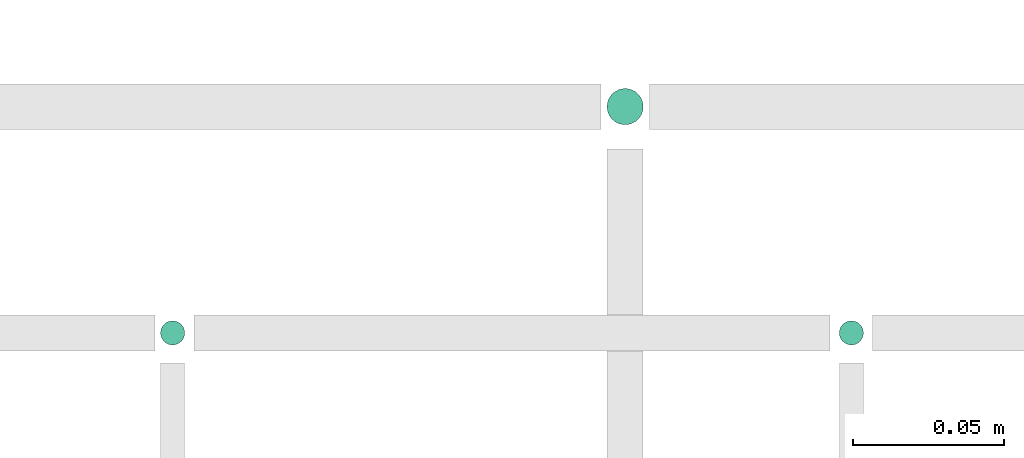
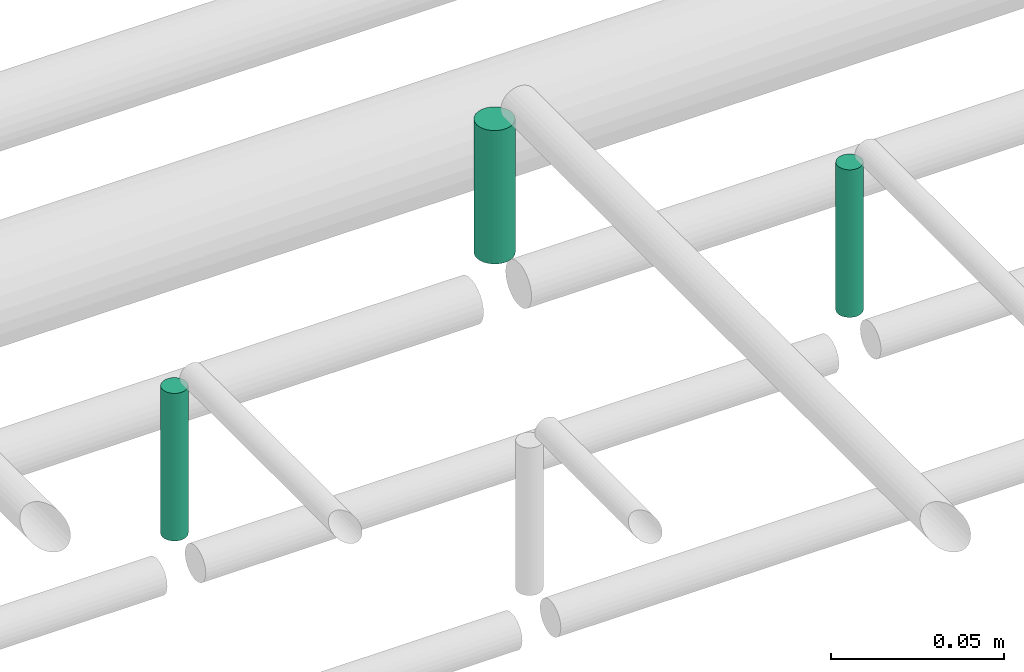
# One storey, part 282 of 331: 3 flow segments.
"""IFC2X3 building model written with IfcOpenShell, lengths in millimetres."""

from ifc_helpers import new_model, entity, si_unit, converted_unit, derived_unit, direction, frame, frame_2d, origin, origin_2d_with_axis, place, context, subcontext, project, spatial, circle, extrude, type_object, element, save


model = new_model("IFC2X3")

# Units and contexts
model_context = context("Model", 3, precision=0.01, world=origin(), true_north=direction((6.12303176911189e-17, 1.0)))
body_context = subcontext(model_context, "Body", "Model", "MODEL_VIEW")
ifc_project = project(units=[si_unit("LENGTHUNIT", "METRE", prefix="MILLI"), si_unit("AREAUNIT", "SQUARE_METRE"), si_unit("VOLUMEUNIT", "CUBIC_METRE"), converted_unit("PLANEANGLEUNIT", "DEGREE", entity("IfcRatioMeasure", 0.0174532925199433), si_unit("PLANEANGLEUNIT", "RADIAN"), dimensions=[0, 0, 0, 0, 0, 0, 0]), si_unit("MASSUNIT", "GRAM", prefix="KILO"), derived_unit("MASSDENSITYUNIT", [(si_unit("MASSUNIT", "GRAM", prefix="KILO"), 1), (si_unit("LENGTHUNIT", "METRE"), -3)]), derived_unit("MOMENTOFINERTIAUNIT", [(si_unit("LENGTHUNIT", "METRE"), 4)]), si_unit("TIMEUNIT", "SECOND"), si_unit("FREQUENCYUNIT", "HERTZ"), si_unit("THERMODYNAMICTEMPERATUREUNIT", "DEGREE_CELSIUS"), derived_unit("THERMALTRANSMITTANCEUNIT", [(si_unit("MASSUNIT", "GRAM", prefix="KILO"), 1), (si_unit("THERMODYNAMICTEMPERATUREUNIT", "KELVIN"), -1), (si_unit("TIMEUNIT", "SECOND"), -3)]), derived_unit("VOLUMETRICFLOWRATEUNIT", [(si_unit("LENGTHUNIT", "METRE"), 3), (si_unit("TIMEUNIT", "SECOND"), -1)]), derived_unit("MASSFLOWRATEUNIT", [(si_unit("MASSUNIT", "GRAM", prefix="KILO"), 1), (si_unit("TIMEUNIT", "SECOND"), -1)]), derived_unit("ROTATIONALFREQUENCYUNIT", [(si_unit("TIMEUNIT", "SECOND"), -1)]), si_unit("ELECTRICCURRENTUNIT", "AMPERE"), si_unit("ELECTRICVOLTAGEUNIT", "VOLT"), si_unit("POWERUNIT", "WATT"), si_unit("FORCEUNIT", "NEWTON", prefix="KILO"), si_unit("ILLUMINANCEUNIT", "LUX"), si_unit("LUMINOUSFLUXUNIT", "LUMEN"), si_unit("LUMINOUSINTENSITYUNIT", "CANDELA"), derived_unit("USERDEFINED", [(si_unit("MASSUNIT", "GRAM", prefix="KILO"), -1), (si_unit("LENGTHUNIT", "METRE"), -2), (si_unit("TIMEUNIT", "SECOND"), 3), (si_unit("LUMINOUSFLUXUNIT", "LUMEN"), 1)]), derived_unit("LINEARVELOCITYUNIT", [(si_unit("LENGTHUNIT", "METRE"), 1), (si_unit("TIMEUNIT", "SECOND"), -1)]), si_unit("PRESSUREUNIT", "PASCAL"), derived_unit("USERDEFINED", [(si_unit("LENGTHUNIT", "METRE"), -2), (si_unit("MASSUNIT", "GRAM", prefix="KILO"), 1), (si_unit("TIMEUNIT", "SECOND"), -2)]), derived_unit("LINEARFORCEUNIT", [(si_unit("MASSUNIT", "GRAM", prefix="KILO"), 1), (si_unit("LENGTHUNIT", "METRE"), 1), (si_unit("TIMEUNIT", "SECOND"), -2), (si_unit("LENGTHUNIT", "METRE"), -1)]), derived_unit("PLANARFORCEUNIT", [(si_unit("MASSUNIT", "GRAM", prefix="KILO"), 1), (si_unit("LENGTHUNIT", "METRE"), 1), (si_unit("TIMEUNIT", "SECOND"), -2), (si_unit("LENGTHUNIT", "METRE"), -2)])], contexts=[model_context])

# Site, building, storey
site_placement = place(None, frame((0.0, -0.00077364408347762, 0.0)))
site = spatial("IfcSite", under=ifc_project, at=site_placement, CompositionType="ELEMENT")
building_placement = place(site_placement, origin())
building = spatial("IfcBuilding", under=site, at=building_placement, CompositionType="ELEMENT")
storey_placement = place(building_placement, origin())
storey = spatial("IfcBuildingStorey", under=building, at=storey_placement, CompositionType="ELEMENT", Elevation=0.0)

# Flow segments
pipe_segment_type = type_object("IfcPipeSegmentType", PredefinedType="NOTDEFINED")
flow_segment_1_placement = place(storey_placement, frame((44564.5706481368, 9469.40472776405, 18463.0)))
element("IfcFlowSegment", 1, at=flow_segment_1_placement, inside=storey, type_object=pipe_segment_type, context=body_context, shape_type="SweptSolid", body=[
    extrude(circle(Radius=4.0, at=frame_2d((0.0, 1.08286712929839e-12), x_axis=(1.0, 0.0))), frame((5.59527223591499, 5.59527223591716, 0.0), z_axis=(0.0, 0.0, 1.0), x_axis=(-1.0, 0.0, 0.0)), (0.0, 0.0, 1.0), 51.9999999999925),
])
flow_segment_2_placement = place(storey_placement, frame((44712.5706481368, 9542.40472776404, 18464.0)))
element("IfcFlowSegment", 2, at=flow_segment_2_placement, inside=storey, type_object=pipe_segment_type, context=body_context, shape_type="SweptSolid", body=[
    extrude(circle(Radius=6.0, at=origin_2d_with_axis()), frame((7.59527223591454, 7.59527223591562, 0.0), z_axis=(0.0, 0.0, 1.0), x_axis=(-1.0, 0.0, 0.0)), (0.0, 0.0, 1.0), 47.000000000024),
])
flow_segment_3_placement = place(storey_placement, frame((44789.5706481369, 9469.404727764, 18463.0)))
element("IfcFlowSegment", 3, at=flow_segment_3_placement, inside=storey, type_object=pipe_segment_type, context=body_context, shape_type="SweptSolid", body=[
    extrude(circle(Radius=4.0, at=frame_2d((0.0, -1.08286712929839e-12), x_axis=(1.0, 0.0))), frame((5.59527223591499, 5.59527223591499, 0.0), z_axis=(0.0, 0.0, 1.0), x_axis=(-1.0, 0.0, 0.0)), (0.0, 0.0, 1.0), 52.0000000000207),
])

save(model, "model.ifc")
